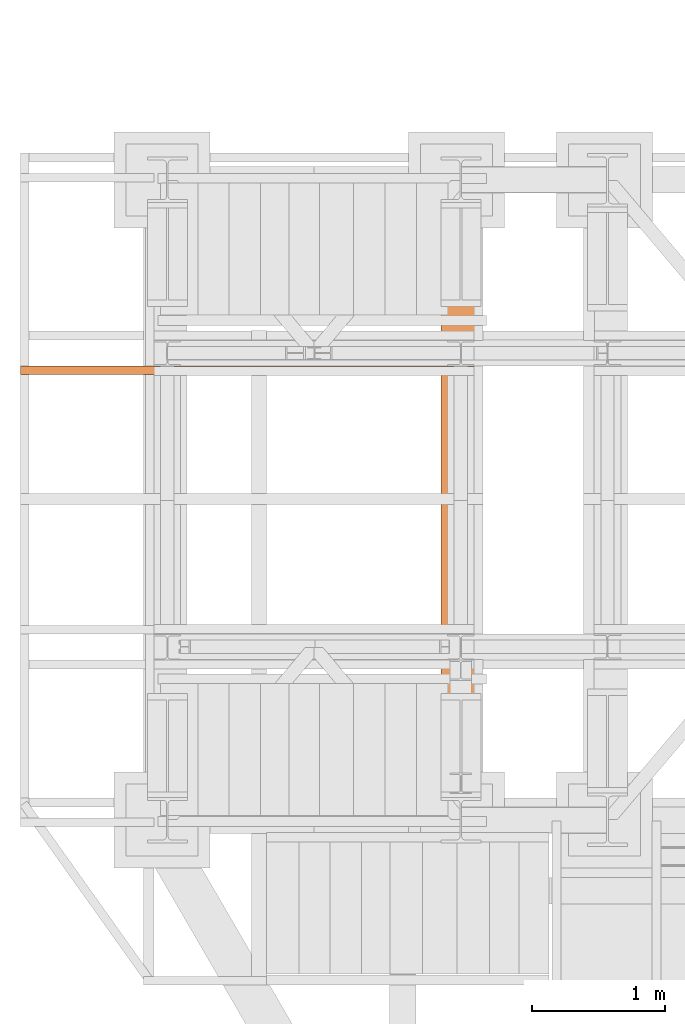
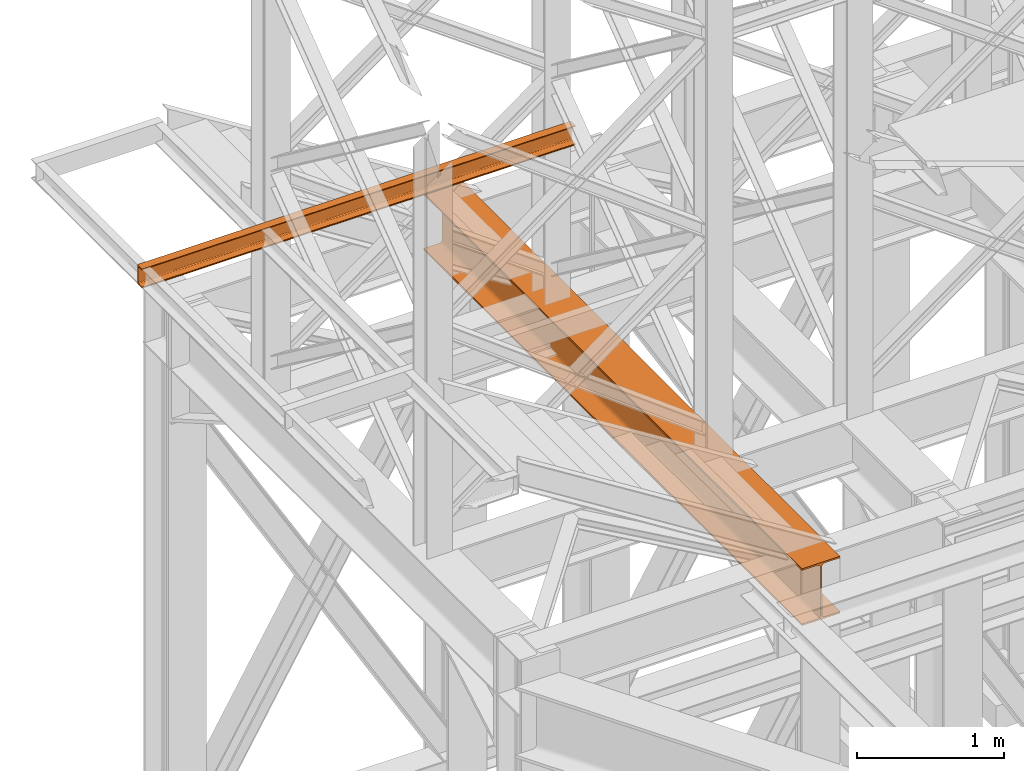
# One storey, part 98 of 208: 2 proxies.
"""IFC2X3 building model written with IfcOpenShell, lengths in millimetres."""

from ifc_helpers import new_model, entity, si_unit, converted_unit, frame, origin, origin_with_axes, place, context, subcontext, project, spatial, faceted_brep, element, save


model = new_model("IFC2X3")

# Units and contexts
model_context = context("Model", 3, precision=1e-05, world=origin())
plan_context = context("Plan", 3, precision=1e-05, world=origin())
body_context = subcontext(model_context, "Body", "Model", "MODEL_VIEW")
ifc_project = project(units=[si_unit("LENGTHUNIT", "METRE", prefix="MILLI"), converted_unit("PLANEANGLEUNIT", "DEGREE", entity("IfcPlaneAngleMeasure", 0.0174532925199433), si_unit("PLANEANGLEUNIT", "RADIAN"), dimensions=[0, 0, 0, 0, 0, 0, 0]), si_unit("AREAUNIT", "SQUARE_METRE"), si_unit("VOLUMEUNIT", "CUBIC_METRE")], contexts=[model_context, plan_context])

# Building, storey
building_placement = place(None, origin())
building = spatial("IfcBuilding", under=ifc_project, at=building_placement, CompositionType="COMPLEX")
storey_placement = place(building_placement, origin_with_axes())
storey = spatial("IfcBuildingStorey", under=building, at=storey_placement, Name="Geschoss", CompositionType="ELEMENT")

# Proxies
proxy_1_placement = place(storey_placement, frame((-1256.566093322735, -17432.57439531565, 4812.990005364416), z_axis=(0.0, 0.0, 1.0), x_axis=(1.0, 0.0, 0.0)))
element("IfcBuildingElementProxy", 1, at=proxy_1_placement, inside=storey, context=body_context, shape_type="Brep", body=[
    faceted_brep([(300.01, 0.00999999999839929, 472.0100000000002), (300.01, 5140.010003576275, 472.0100000000002), (300.01, 5140.010003576275, 458.0100000000002), (300.01, 0.00999999999839929, 458.0100000000002), (300.01, 0.00999999999839929, 458.0100000000002), (300.01, 5140.010003576275, 458.0100000000002), (182.26, 5140.010003576275, 458.0100000000002), (182.26, 0.00999999999839929, 458.0100000000002), (182.26, 0.00999999999839929, 458.0100000000002), (182.26, 5140.010003576275, 458.0100000000002), (173.9165694541387, 5140.010003576275, 456.6884339422595), (173.9165694541387, 0.00999999999839929, 456.6884339422595), (173.9165694541387, 0.00999999999839929, 456.6884339422595), (173.9165694541387, 5140.010003576275, 456.6884339422595), (166.3898249341999, 5140.010003576275, 452.8534254634024), (166.3898249341999, 0.00999999999839929, 452.8534254634024), (166.3898249341999, 0.00999999999839929, 452.8534254634024), (166.3898249341999, 5140.010003576275, 452.8534254634024), (160.4165745365988, 5140.010003576275, 446.8801750658013), (160.4165745365988, 0.00999999999839929, 446.8801750658013), (160.4165745365988, 0.00999999999839929, 446.8801750658013), (160.4165745365988, 5140.010003576275, 446.8801750658013), (156.5815660577407, 5140.010003576275, 439.3534305458607), (156.5815660577407, 0.00999999999839929, 439.3534305458607), (156.5815660577407, 0.00999999999839929, 439.3534305458607), (156.5815660577407, 5140.010003576275, 439.3534305458607), (155.26, 5140.010003576275, 431.0100000000002), (155.26, 0.00999999999839929, 431.0100000000002), (155.26, 0.00999999999839929, 431.0100000000002), (155.26, 5140.010003576275, 431.0100000000002), (155.26, 5140.010003576275, 41.01000000000022), (155.26, 0.00999999999839929, 41.01000000000022), (155.26, 0.00999999999839929, 41.01000000000022), (155.26, 5140.010003576275, 41.01000000000022), (156.5815660577407, 5140.010003576275, 32.66656945413979), (156.5815660577407, 0.00999999999839929, 32.66656945413979), (156.5815660577407, 0.00999999999839929, 32.66656945413979), (156.5815660577407, 5140.010003576275, 32.66656945413979), (160.4165745365988, 5140.010003576275, 25.13982493419826), (160.4165745365988, 0.00999999999839929, 25.13982493419826), (160.4165745365988, 0.00999999999839929, 25.13982493419826), (160.4165745365988, 5140.010003576275, 25.13982493419826), (166.3898249341999, 5140.010003576275, 19.16657453659809), (166.3898249341999, 0.00999999999839929, 19.16657453659809), (166.3898249341999, 0.00999999999839929, 19.16657453659809), (166.3898249341999, 5140.010003576275, 19.16657453659809), (173.9165694541387, 5140.010003576275, 15.33156605774093), (173.9165694541387, 0.00999999999839929, 15.33156605774093), (173.9165694541387, 0.00999999999839929, 15.33156605774093), (173.9165694541387, 5140.010003576275, 15.33156605774093), (182.26, 5140.010003576275, 14.01000000000022), (182.26, 0.00999999999839929, 14.01000000000022), (182.26, 0.00999999999839929, 14.01000000000022), (182.26, 5140.010003576275, 14.01000000000022), (300.01, 5140.010003576275, 14.01000000000022), (300.01, 0.00999999999839929, 14.01000000000022), (300.01, 0.00999999999839929, 14.01000000000022), (300.01, 5140.010003576275, 14.01000000000022), (300.01, 5140.010003576275, 0.01000000000021828), (300.01, 0.00999999999839929, 0.01000000000021828), (300.01, 0.00999999999839929, 0.01000000000021828), (300.01, 5140.010003576275, 0.01000000000021828), (0.009999999999990905, 5140.010003576275, 0.01000000000021828), (0.009999999999990905, 0.00999999999839929, 0.01000000000021828), (0.009999999999990905, 0.00999999999839929, 0.01000000000021828), (0.009999999999990905, 5140.010003576275, 0.01000000000021828), (0.009999999999990905, 5140.010003576275, 14.01000000000022), (0.009999999999990905, 0.00999999999839929, 14.01000000000022), (0.009999999999990905, 0.00999999999839929, 14.01000000000022), (0.009999999999990905, 5140.010003576275, 14.01000000000022), (117.76, 5140.010003576275, 14.01000000000022), (117.76, 0.00999999999839929, 14.01000000000022), (117.76, 0.00999999999839929, 14.01000000000022), (117.76, 5140.010003576275, 14.01000000000022), (126.1034305458613, 5140.010003576275, 15.33156605774093), (126.1034305458613, 0.00999999999839929, 15.33156605774093), (126.1034305458613, 0.00999999999839929, 15.33156605774093), (126.1034305458613, 5140.010003576275, 15.33156605774093), (133.6301750658001, 5140.010003576275, 19.16657453659809), (133.6301750658001, 0.00999999999839929, 19.16657453659809), (133.6301750658001, 0.00999999999839929, 19.16657453659809), (133.6301750658001, 5140.010003576275, 19.16657453659809), (139.6034254634012, 5140.010003576275, 25.13982493419826), (139.6034254634012, 0.00999999999839929, 25.13982493419826), (139.6034254634012, 0.00999999999839929, 25.13982493419826), (139.6034254634012, 5140.010003576275, 25.13982493419826), (143.4384339422593, 5140.010003576275, 32.66656945413979), (143.4384339422593, 0.00999999999839929, 32.66656945413979), (143.4384339422593, 0.00999999999839929, 32.66656945413979), (143.4384339422593, 5140.010003576275, 32.66656945413979), (144.76, 5140.010003576275, 41.01000000000022), (144.76, 0.00999999999839929, 41.01000000000022), (144.76, 0.00999999999839929, 41.01000000000022), (144.76, 5140.010003576275, 41.01000000000022), (144.76, 5140.010003576275, 431.0100000000002), (144.76, 0.00999999999839929, 431.0100000000002), (144.76, 0.00999999999839929, 431.0100000000002), (144.76, 5140.010003576275, 431.0100000000002), (143.4384339422593, 5140.010003576275, 439.3534305458607), (143.4384339422593, 0.00999999999839929, 439.3534305458607), (143.4384339422593, 0.00999999999839929, 439.3534305458607), (143.4384339422593, 5140.010003576275, 439.3534305458607), (139.6034254634012, 5140.010003576275, 446.8801750658013), (139.6034254634012, 0.00999999999839929, 446.8801750658013), (139.6034254634012, 0.00999999999839929, 446.8801750658013), (139.6034254634012, 5140.010003576275, 446.8801750658013), (133.6301750658001, 5140.010003576275, 452.8534254634024), (133.6301750658001, 0.00999999999839929, 452.8534254634024), (133.6301750658001, 0.00999999999839929, 452.8534254634024), (133.6301750658001, 5140.010003576275, 452.8534254634024), (126.1034305458613, 5140.010003576275, 456.6884339422595), (126.1034305458613, 0.00999999999839929, 456.6884339422595), (126.1034305458613, 0.00999999999839929, 456.6884339422595), (126.1034305458613, 5140.010003576275, 456.6884339422595), (117.76, 5140.010003576275, 458.0100000000002), (117.76, 0.00999999999839929, 458.0100000000002), (117.76, 0.00999999999839929, 458.0100000000002), (117.76, 5140.010003576275, 458.0100000000002), (0.009999999999990905, 5140.010003576275, 458.0100000000002), (0.009999999999990905, 0.00999999999839929, 458.0100000000002), (0.009999999999990905, 0.00999999999839929, 458.0100000000002), (0.009999999999990905, 5140.010003576275, 458.0100000000002), (0.009999999999990905, 5140.010003576275, 472.0100000000002), (0.009999999999990905, 0.00999999999839929, 472.0100000000002), (0.009999999999990905, 0.00999999999839929, 472.0100000000002), (0.009999999999990905, 5140.010003576275, 472.0100000000002), (300.01, 5140.010003576275, 472.0100000000002), (300.01, 0.00999999999839929, 472.0100000000002), (300.01, 0.00999999999839929, 472.0100000000002), (300.01, 0.00999999999839929, 458.0100000000002), (182.26, 0.00999999999839929, 458.0100000000002), (173.9165694541387, 0.00999999999839929, 456.6884339422595), (166.3898249341999, 0.00999999999839929, 452.8534254634024), (160.4165745365988, 0.00999999999839929, 446.8801750658013), (156.5815660577407, 0.00999999999839929, 439.3534305458607), (155.26, 0.00999999999839929, 431.0100000000002), (155.26, 0.00999999999839929, 41.01000000000022), (156.5815660577407, 0.00999999999839929, 32.66656945413979), (160.4165745365988, 0.00999999999839929, 25.13982493419826), (166.3898249341999, 0.00999999999839929, 19.16657453659809), (173.9165694541387, 0.00999999999839929, 15.33156605774093), (182.26, 0.00999999999839929, 14.01000000000022), (300.01, 0.00999999999839929, 14.01000000000022), (300.01, 0.00999999999839929, 0.01000000000021828), (0.009999999999990905, 0.00999999999839929, 0.01000000000021828), (0.009999999999990905, 0.00999999999839929, 14.01000000000022), (117.76, 0.00999999999839929, 14.01000000000022), (126.1034305458613, 0.00999999999839929, 15.33156605774093), (133.6301750658001, 0.00999999999839929, 19.16657453659809), (139.6034254634012, 0.00999999999839929, 25.13982493419826), (143.4384339422593, 0.00999999999839929, 32.66656945413979), (144.76, 0.00999999999839929, 41.01000000000022), (144.76, 0.00999999999839929, 431.0100000000002), (143.4384339422593, 0.00999999999839929, 439.3534305458607), (139.6034254634012, 0.00999999999839929, 446.8801750658013), (133.6301750658001, 0.00999999999839929, 452.8534254634024), (126.1034305458613, 0.00999999999839929, 456.6884339422595), (117.76, 0.00999999999839929, 458.0100000000002), (0.009999999999990905, 0.00999999999839929, 458.0100000000002), (0.009999999999990905, 0.00999999999839929, 472.0100000000002), (300.01, 5140.010003576275, 472.0100000000002), (0.009999999999990905, 5140.010003576275, 472.0100000000002), (0.009999999999990905, 5140.010003576275, 458.0100000000002), (117.76, 5140.010003576275, 458.0100000000002), (126.1034305458613, 5140.010003576275, 456.6884339422595), (133.6301750658001, 5140.010003576275, 452.8534254634024), (139.6034254634012, 5140.010003576275, 446.8801750658013), (143.4384339422593, 5140.010003576275, 439.3534305458607), (144.76, 5140.010003576275, 431.0100000000002), (144.76, 5140.010003576275, 41.01000000000022), (143.4384339422593, 5140.010003576275, 32.66656945413979), (139.6034254634012, 5140.010003576275, 25.13982493419826), (133.6301750658001, 5140.010003576275, 19.16657453659809), (126.1034305458613, 5140.010003576275, 15.33156605774093), (117.76, 5140.010003576275, 14.01000000000022), (0.009999999999990905, 5140.010003576275, 14.01000000000022), (0.009999999999990905, 5140.010003576275, 0.01000000000021828), (300.01, 5140.010003576275, 0.01000000000021828), (300.01, 5140.010003576275, 14.01000000000022), (182.26, 5140.010003576275, 14.01000000000022), (173.9165694541387, 5140.010003576275, 15.33156605774093), (166.3898249341999, 5140.010003576275, 19.16657453659809), (160.4165745365988, 5140.010003576275, 25.13982493419826), (156.5815660577407, 5140.010003576275, 32.66656945413979), (155.26, 5140.010003576275, 41.01000000000022), (155.26, 5140.010003576275, 431.0100000000002), (156.5815660577407, 5140.010003576275, 439.3534305458607), (160.4165745365988, 5140.010003576275, 446.8801750658013), (166.3898249341999, 5140.010003576275, 452.8534254634024), (173.9165694541387, 5140.010003576275, 456.6884339422595), (182.26, 5140.010003576275, 458.0100000000002), (300.01, 5140.010003576275, 458.0100000000002)], [[[0, 1, 2, 3]], [[4, 5, 6, 7]], [[8, 9, 10, 11]], [[12, 13, 14, 15]], [[16, 17, 18, 19]], [[20, 21, 22, 23]], [[24, 25, 26, 27]], [[28, 29, 30, 31]], [[32, 33, 34, 35]], [[36, 37, 38, 39]], [[40, 41, 42, 43]], [[44, 45, 46, 47]], [[48, 49, 50, 51]], [[52, 53, 54, 55]], [[56, 57, 58, 59]], [[60, 61, 62, 63]], [[64, 65, 66, 67]], [[68, 69, 70, 71]], [[72, 73, 74, 75]], [[76, 77, 78, 79]], [[80, 81, 82, 83]], [[84, 85, 86, 87]], [[88, 89, 90, 91]], [[92, 93, 94, 95]], [[96, 97, 98, 99]], [[100, 101, 102, 103]], [[104, 105, 106, 107]], [[108, 109, 110, 111]], [[112, 113, 114, 115]], [[116, 117, 118, 119]], [[120, 121, 122, 123]], [[124, 125, 126, 127]], [[128, 129, 130, 131, 132, 133, 134, 135, 136, 137, 138, 139, 140, 141, 142, 143, 144, 145, 146, 147, 148, 149, 150, 151, 152, 153, 154, 155, 156, 157, 158, 159]], [[160, 161, 162, 163, 164, 165, 166, 167, 168, 169, 170, 171, 172, 173, 174, 175, 176, 177, 178, 179, 180, 181, 182, 183, 184, 185, 186, 187, 188, 189, 190, 191]]], orient=[[False], [False], [False], [False], [False], [False], [False], [False], [False], [False], [False], [False], [False], [False], [False], [False], [False], [False], [False], [False], [False], [False], [False], [False], [False], [False], [False], [False], [False], [False], [False], [False], [False], [False]]),
])
proxy_2_placement = place(storey_placement, frame((-4406.745032961453, -13922.57439657638, 6584.990005364416), z_axis=(0.0, 0.0, 1.0), x_axis=(1.0, 0.0, 0.0)))
element("IfcBuildingElementProxy", 2, at=proxy_2_placement, inside=storey, context=body_context, shape_type="Brep", body=[
    faceted_brep([(0.01000000000021828, 0.01000000000021828, 0.01000000000021828), (0.01000000000021828, 0.01000000000021828, 3.132428070246533), (3400.172281612573, 0.01000000000021828, 3.132428070246533), (3400.172281612573, 0.01000000000021828, 0.01000000000021828), (0.01000000000021828, 0.01000000000021828, 3.132428070246533), (0.01000000000021828, 0.2527365771748009, 4.748288908171162), (3400.172281612573, 0.2527365771729819, 4.748288908171162), (3400.172281612573, 0.01000000000021828, 3.132428070246533), (0.01000000000021828, 0.2527365771748009, 4.748288908171162), (0.01000000000021828, 0.959467714144921, 6.221534443444398), (3400.172281612573, 0.9594677141431021, 6.221534443444398), (3400.172281612573, 0.2527365771729819, 4.748288908171162), (0.01000000000021828, 0.959467714144921, 6.221534443444398), (0.01000000000021828, 2.067848361532015, 7.422126703873801), (3400.172281612573, 2.067848361530196, 7.422126703873801), (3400.172281612573, 0.9594677141431021, 6.221534443444398), (0.01000000000021828, 2.067848361532015, 7.422126703873801), (0.01000000000021828, 3.4800435885154, 8.244091391710754), (3400.172281612573, 3.4800435885154, 8.244091391710754), (3400.172281612573, 2.067848361530196, 7.422126703873801), (0.01000000000021828, 3.4800435885154, 8.244091391710754), (0.01000000000021828, 5.071401277444238, 8.614912102195376), (3400.172281612573, 5.071401277444238, 8.614912102195376), (3400.172281612573, 3.4800435885154, 8.244091391710754), (0.01000000000021828, 5.071401277444238, 8.614912102195376), (0.01000000000021828, 47.84732483397056, 12.0369859867169), (3400.172281612573, 47.84732483397056, 12.0369859867169), (3400.172281612573, 5.071401277444238, 8.614912102195376), (0.01000000000021828, 47.84732483397056, 12.0369859867169), (0.01000000000021828, 50.88537133101636, 12.74491643400506), (3400.172281612573, 50.88537133101636, 12.74491643400506), (3400.172281612573, 47.84732483397056, 12.0369859867169), (0.01000000000021828, 50.88537133101636, 12.74491643400506), (0.01000000000021828, 53.5813804007139, 14.31412174714933), (3400.172281612573, 53.58138040071208, 14.31412174714933), (3400.172281612573, 50.88537133101636, 12.74491643400506), (0.01000000000021828, 53.5813804007139, 14.31412174714933), (0.01000000000021828, 55.69737981845356, 16.60616151705835), (3400.172281612573, 55.69737981845174, 16.60616151705835), (3400.172281612573, 53.58138040071208, 14.31412174714933), (0.01000000000021828, 55.69737981845356, 16.60616151705835), (0.01000000000021828, 57.04659380721569, 19.41872117530875), (3400.172281612573, 57.04659380721387, 19.41872117530875), (3400.172281612573, 55.69737981845174, 16.60616151705835), (0.01000000000021828, 57.04659380721569, 19.41872117530875), (0.01000000000021828, 57.51000000000022, 22.50354641134618), (3400.172281612573, 57.51000000000022, 22.50354641134618), (3400.172281612573, 57.04659380721387, 19.41872117530875), (0.01000000000021828, 57.51000000000022, 22.50354641134618), (0.01000000000021828, 57.51000000000022, 137.5164535886524), (3400.172281612573, 57.51000000000022, 137.5164535886524), (3400.172281612573, 57.51000000000022, 22.50354641134618), (0.01000000000021828, 57.51000000000022, 137.5164535886524), (0.01000000000021828, 57.04659380721569, 140.6012788246917), (3400.172281612573, 57.04659380721387, 140.6012788246917), (3400.172281612573, 57.51000000000022, 137.5164535886524), (0.01000000000021828, 57.04659380721569, 140.6012788246917), (0.01000000000021828, 55.69737981845356, 143.4138384829403), (3400.172281612573, 55.69737981845174, 143.4138384829403), (3400.172281612573, 57.04659380721387, 140.6012788246917), (0.01000000000021828, 55.69737981845356, 143.4138384829403), (0.01000000000021828, 53.5813804007139, 145.7058782528493), (3400.172281612573, 53.58138040071208, 145.7058782528493), (3400.172281612573, 55.69737981845174, 143.4138384829403), (0.01000000000021828, 53.5813804007139, 145.7058782528493), (0.01000000000021828, 50.88537133101636, 147.2750835659936), (3400.172281612573, 50.88537133101636, 147.2750835659936), (3400.172281612573, 53.58138040071208, 145.7058782528493), (0.01000000000021828, 50.88537133101636, 147.2750835659936), (0.01000000000021828, 47.84732483397056, 147.9830140132817), (3400.172281612573, 47.84732483397056, 147.9830140132817), (3400.172281612573, 50.88537133101636, 147.2750835659936), (0.01000000000021828, 47.84732483397056, 147.9830140132817), (0.01000000000021828, 5.071401277444238, 151.4050878978032), (3400.172281612573, 5.071401277444238, 151.4050878978032), (3400.172281612573, 47.84732483397056, 147.9830140132817), (0.01000000000021828, 5.071401277444238, 151.4050878978032), (0.01000000000021828, 3.4800435885154, 151.7759086082879), (3400.172281612573, 3.4800435885154, 151.7759086082879), (3400.172281612573, 5.071401277444238, 151.4050878978032), (0.01000000000021828, 3.4800435885154, 151.7759086082879), (0.01000000000021828, 2.067848361532015, 152.5978732961248), (3400.172281612573, 2.067848361530196, 152.5978732961248), (3400.172281612573, 3.4800435885154, 151.7759086082879), (0.01000000000021828, 2.067848361532015, 152.5978732961248), (0.01000000000021828, 0.959467714144921, 153.7984655565542), (3400.172281612573, 0.9594677141431021, 153.7984655565542), (3400.172281612573, 2.067848361530196, 152.5978732961248), (0.01000000000021828, 0.959467714144921, 153.7984655565542), (0.01000000000021828, 0.2527365771748009, 155.2717110918275), (3400.172281612573, 0.2527365771729819, 155.2717110918275), (3400.172281612573, 0.9594677141431021, 153.7984655565542), (0.01000000000021828, 0.2527365771748009, 155.2717110918275), (0.01000000000021828, 0.01000000000021828, 156.8875719297521), (3400.172281612573, 0.01000000000021828, 156.8875719297521), (3400.172281612573, 0.2527365771729819, 155.2717110918275), (0.01000000000021828, 0.01000000000021828, 156.8875719297521), (0.01000000000021828, 0.01000000000021828, 160.0100000000002), (3400.172281612573, 0.01000000000021828, 160.0100000000002), (3400.172281612573, 0.01000000000021828, 156.8875719297521), (0.01000000000021828, 0.01000000000021828, 160.0100000000002), (0.01000000000021828, 65.01000000000022, 160.0100000000002), (3400.172281612573, 65.01000000000022, 160.0100000000002), (3400.172281612573, 0.01000000000021828, 160.0100000000002), (0.01000000000021828, 65.01000000000022, 160.0100000000002), (0.01000000000021828, 65.01000000000022, 0.01000000000021828), (3400.172281612573, 65.01000000000022, 0.01000000000021828), (3400.172281612573, 65.01000000000022, 160.0100000000002), (0.01000000000021828, 65.01000000000022, 0.01000000000021828), (0.01000000000021828, 0.01000000000021828, 0.01000000000021828), (3400.172281612573, 0.01000000000021828, 0.01000000000021828), (3400.172281612573, 65.01000000000022, 0.01000000000021828), (0.01000000000021828, 0.01000000000021828, 0.01000000000021828), (0.01000000000021828, 65.01000000000022, 0.01000000000021828), (0.01000000000021828, 65.01000000000022, 160.0100000000002), (0.01000000000021828, 0.01000000000021828, 160.0100000000002), (0.01000000000021828, 0.01000000000021828, 156.8875719297521), (0.01000000000021828, 0.2527365771748009, 155.2717110918275), (0.01000000000021828, 0.959467714144921, 153.7984655565542), (0.01000000000021828, 2.067848361532015, 152.5978732961248), (0.01000000000021828, 3.4800435885154, 151.7759086082879), (0.01000000000021828, 5.071401277444238, 151.4050878978032), (0.01000000000021828, 47.84732483397056, 147.9830140132817), (0.01000000000021828, 50.88537133101636, 147.2750835659936), (0.01000000000021828, 53.5813804007139, 145.7058782528493), (0.01000000000021828, 55.69737981845356, 143.4138384829403), (0.01000000000021828, 57.04659380721569, 140.6012788246917), (0.01000000000021828, 57.51000000000022, 137.5164535886524), (0.01000000000021828, 57.51000000000022, 22.50354641134618), (0.01000000000021828, 57.04659380721569, 19.41872117530875), (0.01000000000021828, 55.69737981845356, 16.60616151705835), (0.01000000000021828, 53.5813804007139, 14.31412174714933), (0.01000000000021828, 50.88537133101636, 12.74491643400506), (0.01000000000021828, 47.84732483397056, 12.0369859867169), (0.01000000000021828, 5.071401277444238, 8.614912102195376), (0.01000000000021828, 3.4800435885154, 8.244091391710754), (0.01000000000021828, 2.067848361532015, 7.422126703873801), (0.01000000000021828, 0.959467714144921, 6.221534443444398), (0.01000000000021828, 0.2527365771748009, 4.748288908171162), (0.01000000000021828, 0.01000000000021828, 3.132428070246533), (3400.172281612573, 0.01000000000021828, 0.01000000000021828), (3400.172281612573, 0.01000000000021828, 3.132428070246533), (3400.172281612573, 0.2527365771729819, 4.748288908171162), (3400.172281612573, 0.9594677141431021, 6.221534443444398), (3400.172281612573, 2.067848361530196, 7.422126703873801), (3400.172281612573, 3.4800435885154, 8.244091391710754), (3400.172281612573, 5.071401277444238, 8.614912102195376), (3400.172281612573, 47.84732483397056, 12.0369859867169), (3400.172281612573, 50.88537133101636, 12.74491643400506), (3400.172281612573, 53.58138040071208, 14.31412174714933), (3400.172281612573, 55.69737981845174, 16.60616151705835), (3400.172281612573, 57.04659380721387, 19.41872117530875), (3400.172281612573, 57.51000000000022, 22.50354641134618), (3400.172281612573, 57.51000000000022, 137.5164535886524), (3400.172281612573, 57.04659380721387, 140.6012788246917), (3400.172281612573, 55.69737981845174, 143.4138384829403), (3400.172281612573, 53.58138040071208, 145.7058782528493), (3400.172281612573, 50.88537133101636, 147.2750835659936), (3400.172281612573, 47.84732483397056, 147.9830140132817), (3400.172281612573, 5.071401277444238, 151.4050878978032), (3400.172281612573, 3.4800435885154, 151.7759086082879), (3400.172281612573, 2.067848361530196, 152.5978732961248), (3400.172281612573, 0.9594677141431021, 153.7984655565542), (3400.172281612573, 0.2527365771729819, 155.2717110918275), (3400.172281612573, 0.01000000000021828, 156.8875719297521), (3400.172281612573, 0.01000000000021828, 160.0100000000002), (3400.172281612573, 65.01000000000022, 160.0100000000002), (3400.172281612573, 65.01000000000022, 0.01000000000021828)], [[[0, 1, 2, 3]], [[4, 5, 6, 7]], [[8, 9, 10, 11]], [[12, 13, 14, 15]], [[16, 17, 18, 19]], [[20, 21, 22, 23]], [[24, 25, 26, 27]], [[28, 29, 30, 31]], [[32, 33, 34, 35]], [[36, 37, 38, 39]], [[40, 41, 42, 43]], [[44, 45, 46, 47]], [[48, 49, 50, 51]], [[52, 53, 54, 55]], [[56, 57, 58, 59]], [[60, 61, 62, 63]], [[64, 65, 66, 67]], [[68, 69, 70, 71]], [[72, 73, 74, 75]], [[76, 77, 78, 79]], [[80, 81, 82, 83]], [[84, 85, 86, 87]], [[88, 89, 90, 91]], [[92, 93, 94, 95]], [[96, 97, 98, 99]], [[100, 101, 102, 103]], [[104, 105, 106, 107]], [[108, 109, 110, 111]], [[112, 113, 114, 115, 116, 117, 118, 119, 120, 121, 122, 123, 124, 125, 126, 127, 128, 129, 130, 131, 132, 133, 134, 135, 136, 137, 138, 139]], [[140, 141, 142, 143, 144, 145, 146, 147, 148, 149, 150, 151, 152, 153, 154, 155, 156, 157, 158, 159, 160, 161, 162, 163, 164, 165, 166, 167]]], orient=[[False], [False], [False], [False], [False], [False], [False], [False], [False], [False], [False], [False], [False], [False], [False], [False], [False], [False], [False], [False], [False], [False], [False], [False], [False], [False], [False], [False], [False], [False]]),
])

save(model, "model.ifc")
